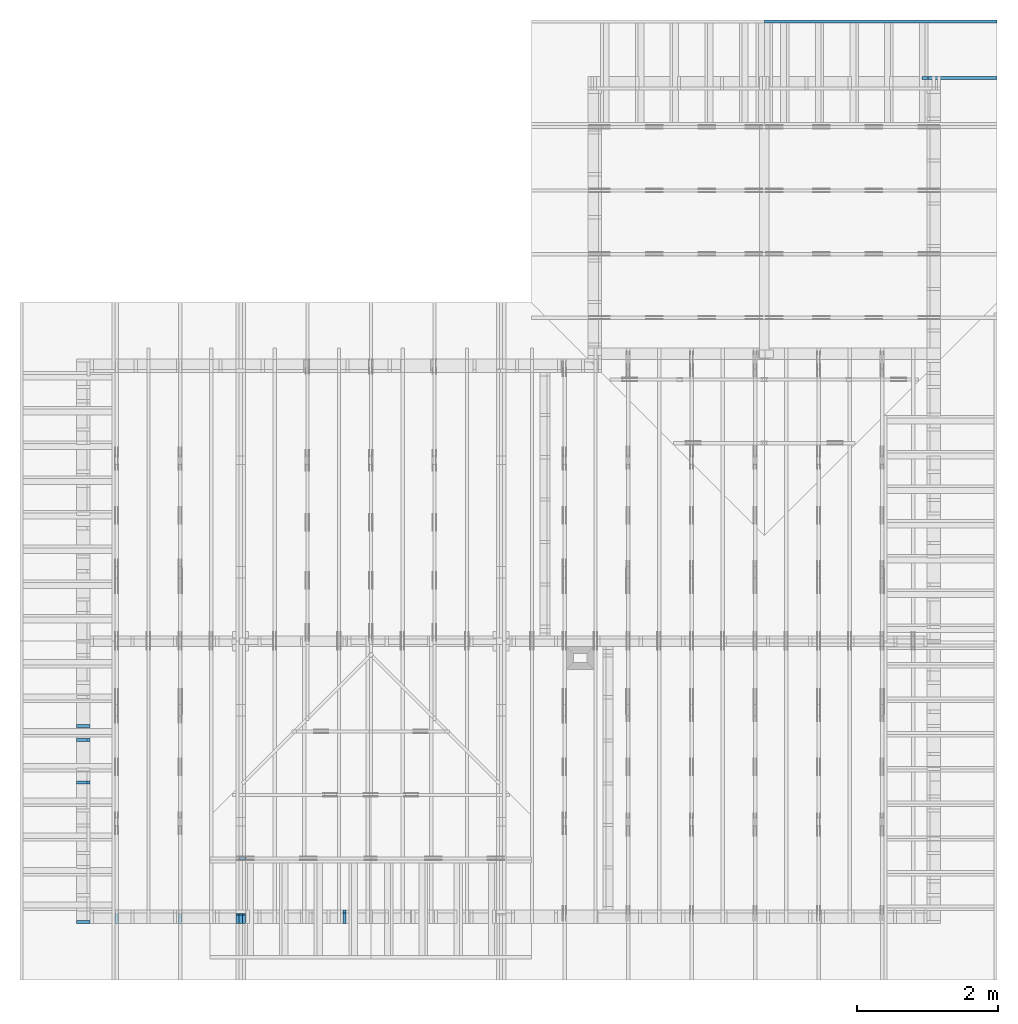
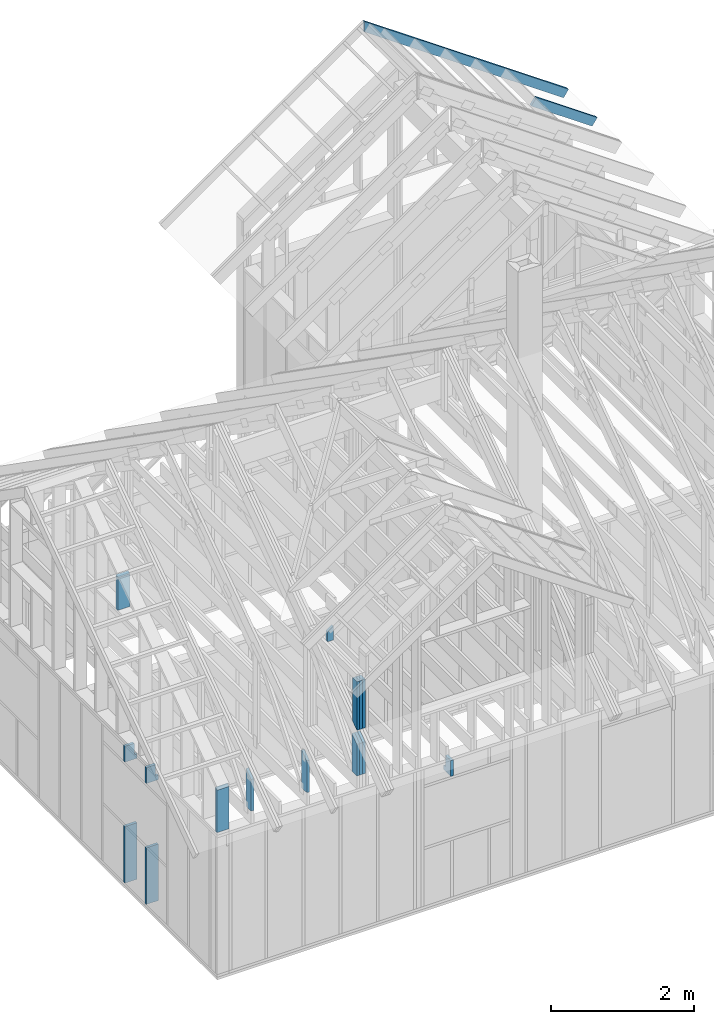
# One storey, part 36 of 70: 18 members, 8 elements without a shape of their own.
"""IFC2X3 building model written with IfcOpenShell, lengths in millimetres."""

import ifcopenshell
import ifcopenshell.guid

model = None  # the IFC model being written
_history = None  # IfcOwnerHistory: only IFC2X3 demands one
_inside = {}  # id of a spatial element -> (the spatial element, [elements in it])
_under = {}  # id of a project, library or spatial element -> (it, [spatial elements below it])
_declared = {}  # id of a project -> (the project, [libraries it declares])
_typed = {}  # id of a type object -> (the type object, [elements of that type])
_made_of = {}  # id of a material, layer set ... -> (it, [elements and type objects made of it])


def new_model(schema):
    """Start an empty IFC model of exactly this schema.

    Asked for "IFC4X3", IfcOpenShell would pick the latest addendum, in which some entities
    have other attributes; the version numbers below select the first issue.
    IFC2X3 requires an IfcOwnerHistory on every rooted entity: one is made here for all.
    """
    global model, _history
    if schema == "IFC4X3":
        model = ifcopenshell.file(schema_version=(4, 3, 0, 0))
    else:
        model = ifcopenshell.file(schema=schema)
    _inside.clear()
    _under.clear()
    _declared.clear()
    _typed.clear()
    _made_of.clear()
    _history = None
    if model.schema == "IFC2X3":
        org = make("IfcOrganization", Name="unknown")
        user = make(
            "IfcPersonAndOrganization",
            ThePerson=make("IfcPerson", FamilyName="unknown"),
            TheOrganization=org,
        )
        app = make(
            "IfcApplication",
            ApplicationDeveloper=org,
            Version="unknown",
            ApplicationFullName="unknown",
            ApplicationIdentifier="unknown",
        )
        _history = make(
            "IfcOwnerHistory",
            OwningUser=user,
            OwningApplication=app,
            ChangeAction="ADDED",
            CreationDate=0,
        )
    return model


def make(cls, **values):
    """One entity of the class cls with the attributes given. An attribute that is None is left unset."""
    return model.create_entity(
        cls, **{name: value for name, value in values.items() if value is not None}
    )


def rooted(cls, **values):
    """An entity with a GlobalId (a new one), such as an element, a storey or a relation."""
    return make(cls, GlobalId=ifcopenshell.guid.new(), OwnerHistory=_history, **values)


def si_unit(unit_type, name, prefix=None):
    """IfcSIUnit, for example si_unit("LENGTHUNIT", "METRE", prefix="MILLI")."""
    return make("IfcSIUnit", UnitType=unit_type, Prefix=prefix, Name=name)


def assignment(units):
    """IfcUnitAssignment: the units of a project."""
    return None if units is None else make("IfcUnitAssignment", Units=units)


def point(xyz):
    """IfcCartesianPoint."""
    return None if xyz is None else make("IfcCartesianPoint", Coordinates=xyz)


def direction(xyz):
    """IfcDirection."""
    return None if xyz is None else make("IfcDirection", DirectionRatios=xyz)


def frame(location, z_axis=None, x_axis=None):
    """IfcAxis2Placement3D, a coordinate frame: its origin and axes. An axis left out is left unset."""
    return make(
        "IfcAxis2Placement3D",
        Location=point(location),
        Axis=direction(z_axis),
        RefDirection=direction(x_axis),
    )


def frame_2d(location, x_axis=None):
    """IfcAxis2Placement2D, a coordinate frame in the plane: its origin and x axis."""
    return make(
        "IfcAxis2Placement2D", Location=point(location), RefDirection=direction(x_axis)
    )


def origin():
    """The frame at (0, 0, 0) with its axes left unset."""
    return frame((0.0, 0.0, 0.0))


def origin_with_axes():
    """The frame at (0, 0, 0) with the z axis (0, 0, 1) and the x axis (1, 0, 0) written out."""
    return frame((0.0, 0.0, 0.0), z_axis=(0.0, 0.0, 1.0), x_axis=(1.0, 0.0, 0.0))


def origin_2d():
    """The frame at (0, 0) in the plane with its x axis left unset."""
    return frame_2d((0.0, 0.0))


def place(relative_to, where):
    """IfcLocalPlacement: puts the frame where relative to a parent placement (None: the world)."""
    return make(
        "IfcLocalPlacement", PlacementRelTo=relative_to, RelativePlacement=where
    )


def context(
    kind, dimensions, precision=None, world=None, true_north=None, identifier=None
):
    """IfcGeometricRepresentationContext, for example the 3D "Model" context."""
    return make(
        "IfcGeometricRepresentationContext",
        ContextIdentifier=identifier,
        ContextType=kind,
        CoordinateSpaceDimension=dimensions,
        Precision=precision,
        WorldCoordinateSystem=world,
        TrueNorth=true_north,
    )


def project(units=None, contexts=None):
    """IfcProject with its units and contexts."""
    return rooted(
        "IfcProject",
        Name="project",
        RepresentationContexts=contexts,
        UnitsInContext=assignment(units),
    )


def spatial(cls, under=None, at=None, **own):
    """A site, building, storey or space (cls), placed at a placement, below another one or the project."""
    s = rooted(cls, ObjectPlacement=at, **own)
    if under is not None:
        _under.setdefault(under.id(), (under, []))[1].append(s)
    return s


def faces_of(points, faces, orient=None, outer=None):
    """IfcFace entities. A face is a list of loops; a loop is a list of indices into points, from 0.

    orient and outer hold one flag for each loop. By default every Orientation is true, the
    first loop of a face is its IfcFaceOuterBound and the others are IfcFaceBound.
    """
    made = []
    for i, loops in enumerate(faces):
        bounds = []
        for j, loop in enumerate(loops):
            is_outer = j == 0 if outer is None else outer[i][j]
            bounds.append(
                make(
                    "IfcFaceOuterBound" if is_outer else "IfcFaceBound",
                    Bound=make("IfcPolyLoop", Polygon=[points[k] for k in loop]),
                    Orientation=True if orient is None else orient[i][j],
                )
            )
        made.append(make("IfcFace", Bounds=bounds))
    return made


def faceted_brep(points, faces, orient=None, outer=None, voids=None):
    """IfcFacetedBrep: a solid bounded by flat faces; with voids (closed shells), ...WithVoids."""
    shared = [point(p) for p in points]
    hull = make("IfcClosedShell", CfsFaces=faces_of(shared, faces, orient, outer))
    if voids is None:
        return make("IfcFacetedBrep", Outer=hull)
    return make(
        "IfcFacetedBrepWithVoids",
        Outer=hull,
        Voids=[
            make(cls, CfsFaces=faces_of(shared, fs, o, b)) for cls, fs, o, b in voids
        ],
    )


def shape(context_of_items, identifier, shape_type, items):
    """IfcShapeRepresentation: the items that make up one representation, for example the "Body"."""
    return make(
        "IfcShapeRepresentation",
        ContextOfItems=context_of_items,
        RepresentationIdentifier=identifier,
        RepresentationType=shape_type,
        Items=items,
    )


def made_of(thing, what):
    """Note that an element or type object is made of a material, layer set ...; save() writes the relation."""
    if what is not None:
        _made_of.setdefault(what.id(), (what, []))[1].append(thing)
    return thing


def element(
    cls,
    number,
    at=None,
    inside=None,
    cuts=None,
    type_object=None,
    material=None,
    context=None,
    identifier="Body",
    shape_type=None,
    held_by="IfcProductDefinitionShape",
    body=None,
    shapes=None,
    **own,
):
    """One element of the class cls, such as IfcWall. Its Tag is "e" and its number.

    at: its placement. inside: the storey or other place that contains it. cuts: it is an
    opening in that element (IfcRelVoidsElement). A single representation is given by context,
    identifier, shape_type and body (its items); several are given by shapes. held_by: the class
    of the entity that holds the representations. save() writes the other relations.
    """
    e = rooted(cls, Tag="e%d" % number, ObjectPlacement=at, **own)
    if body is not None:
        shapes = [shape(context, identifier, shape_type, body)]
    if shapes is not None:
        e.Representation = make(held_by, Representations=shapes)
    if inside is not None:
        _inside.setdefault(inside.id(), (inside, []))[1].append(e)
    if cuts is not None:
        rooted(
            "IfcRelVoidsElement", RelatingBuildingElement=cuts, RelatedOpeningElement=e
        )
    if type_object is not None:
        _typed.setdefault(type_object.id(), (type_object, []))[1].append(e)
    return made_of(e, material)


def aggregate(whole, parts):
    """IfcRelAggregates: a whole, such as a stair, and the parts it consists of."""
    return rooted("IfcRelAggregates", RelatingObject=whole, RelatedObjects=parts)


def save(model, path):
    """Write the relations noted so far, then the file.

    IfcRelAggregates (storeys below a building ...), IfcRelContainedInSpatialStructure (elements
    in a storey), IfcRelDefinesByType, IfcRelAssociatesMaterial and IfcRelDeclares: one each for
    every whole, place, type object, material and project.
    """
    for whole, parts in _under.values():
        aggregate(whole, parts)
    for where, things in _inside.values():
        rooted(
            "IfcRelContainedInSpatialStructure",
            RelatedElements=things,
            RelatingStructure=where,
        )
    for kind, things in _typed.values():
        rooted("IfcRelDefinesByType", RelatedObjects=things, RelatingType=kind)
    for what, things in _made_of.values():
        rooted("IfcRelAssociatesMaterial", RelatedObjects=things, RelatingMaterial=what)
    for by, libraries in _declared.values():
        rooted("IfcRelDeclares", RelatingContext=by, RelatedDefinitions=libraries)
    model.write(path)


model = new_model("IFC2X3")

# Units and contexts
model_context = context("Model", 3, precision=1e-05, world=origin())
plan_context = context("Plan", 2, precision=1e-05, world=origin_2d())
ifc_project = project(units=[si_unit("LENGTHUNIT", "METRE", prefix="MILLI"), si_unit("AREAUNIT", "SQUARE_METRE"), si_unit("VOLUMEUNIT", "CUBIC_METRE"), si_unit("SOLIDANGLEUNIT", "STERADIAN"), si_unit("PLANEANGLEUNIT", "RADIAN"), si_unit("MASSUNIT", "GRAM"), si_unit("TIMEUNIT", "SECOND"), si_unit("THERMODYNAMICTEMPERATUREUNIT", "DEGREE_CELSIUS"), si_unit("LUMINOUSINTENSITYUNIT", "LUMEN")], contexts=[model_context, plan_context])

# Site, building, storey
site_placement = place(None, origin_with_axes())
site = spatial("IfcSite", under=ifc_project, at=site_placement, CompositionType="ELEMENT")
building_placement = place(site_placement, origin_with_axes())
building = spatial("IfcBuilding", under=site, at=building_placement, Name="Layout 1", CompositionType="ELEMENT")
storey_placement = place(building_placement, origin_with_axes())
storey = spatial("IfcBuildingStorey", under=building, at=storey_placement, Name="Storey 1", CompositionType="ELEMENT", Elevation=0.0)

# Assembly, members
assembly_1_placement = place(storey_placement, frame((1969.9999999999982, 8000.000000000001, 1.1021457184401395e-14), z_axis=(-1.0, 1.836909530733566e-16, 6.123031769111886e-17), x_axis=(-1.836909530733566e-16, -1.0, 0.0)))
assembly_1 = element("IfcElementAssembly", 1, at=assembly_1_placement, inside=storey, Name="T11", AssemblyPlace="FACTORY", PredefinedType="TRUSS")
member_1_placement = place(assembly_1_placement, frame((7855.0, 863.4790482301833, -90.0), z_axis=(0.0, 0.0, 1.0), x_axis=(-1.836909530733566e-16, -1.0, 0.0)))
member_1 = element("IfcMember", 2, at=member_1_placement, Name="E3", context=model_context, shape_type="Brep", body=[
    faceted_brep([(643.4790482301834, 145.0, 45.0), (101.53009304048464, 145.0, 45.0), (0.0, 1.8480932340025902e-09, 45.0), (643.4790482301834, 1.8480932340025902e-09, 45.0), (101.53009304048464, 145.0, 1.2433439704155462e-14), (643.4790482301834, 145.0, 7.880085310142585e-14), (643.4790482301834, 1.8480932340025902e-09, 7.880085310142585e-14), (0.0, 1.8480932340025902e-09, 0.0), (5.452511878872964e-15, 1.8480894161126704e-09, -4.075666256077759e-31), (7.70957417477943e-15, 1.8480878357006368e-09, 45.0), (101.53009304048466, 145.00000000183354, 45.0), (101.53009304048466, 145.00000000183354, 3.1438766626360792e-31), (643.4790482301834, -3.3424355386735616e-13, 2.0465838989515024e-29), (643.4790482301834, -3.314881895712558e-13, 45.0), (7.91492914862017e-27, 1.8480959893668863e-09, 45.0), (0.0, 1.8480932340025902e-09, 0.0), (643.4790482301834, 145.0, 0.0), (643.4790482301834, 145.0, 45.0), (643.4790482301834, 0.0, 45.0), (643.4790482301834, 0.0, 0.0), (101.53009304048464, 145.00000000183357, 1.5777218104420236e-30), (101.53009304048464, 145.00000000183354, 45.0), (643.4790482301834, 145.00000000000006, 45.0), (643.4790482301834, 145.00000000000006, 4.733165431326071e-30)], [[[0, 1, 2, 3]], [[4, 5, 6, 7]], [[8, 9, 10, 11]], [[12, 13, 14, 15]], [[16, 17, 18, 19]], [[20, 21, 22, 23]]]),
])
member_2_placement = place(assembly_1_placement, frame((7855.0, 863.4790482301833, -135.0), z_axis=(0.0, 0.0, 1.0), x_axis=(-1.836909530733566e-16, -1.0, 0.0)))
member_2 = element("IfcMember", 3, at=member_2_placement, Name="E3", context=model_context, shape_type="Brep", body=[
    faceted_brep([(643.4790482301834, 145.0, 45.0), (101.53009304048464, 145.0, 45.0), (0.0, 1.8480932340025902e-09, 45.0), (643.4790482301834, 1.8480932340025902e-09, 45.0), (101.53009304048464, 145.0, 1.2433439704155462e-14), (643.4790482301834, 145.0, 7.880085310142585e-14), (643.4790482301834, 1.8480932340025902e-09, 7.880085310142585e-14), (0.0, 1.8480932340025902e-09, 0.0), (5.452511878872964e-15, 1.8480894161126704e-09, -4.075666256077759e-31), (7.70957417477943e-15, 1.8480878357006368e-09, 45.0), (101.53009304048466, 145.00000000183354, 45.0), (101.53009304048466, 145.00000000183354, 3.1438766626360792e-31), (643.4790482301834, -3.3424355386735616e-13, 2.0465838989515024e-29), (643.4790482301834, -3.314881895712558e-13, 45.0), (7.91492914862017e-27, 1.8480959893668863e-09, 45.0), (0.0, 1.8480932340025902e-09, 0.0), (643.4790482301834, 145.0, 0.0), (643.4790482301834, 145.0, 45.0), (643.4790482301834, 0.0, 45.0), (643.4790482301834, 0.0, 0.0), (101.53009304048464, 145.00000000183357, 1.5777218104420236e-30), (101.53009304048464, 145.00000000183354, 45.0), (643.4790482301834, 145.00000000000006, 45.0), (643.4790482301834, 145.00000000000006, 4.733165431326071e-30)], [[[0, 1, 2, 3]], [[4, 5, 6, 7]], [[8, 9, 10, 11]], [[12, 13, 14, 15]], [[16, 17, 18, 19]], [[20, 21, 22, 23]]]),
])
member_3_placement = place(assembly_1_placement, frame((7855.0, 863.4790482301833, -180.0), z_axis=(0.0, 0.0, 1.0), x_axis=(-1.836909530733566e-16, -1.0, 0.0)))
member_3 = element("IfcMember", 4, at=member_3_placement, Name="E3", context=model_context, shape_type="Brep", body=[
    faceted_brep([(643.4790482301834, 145.0, 45.0), (101.53009304048464, 145.0, 45.0), (0.0, 1.8480932340025902e-09, 45.0), (643.4790482301834, 1.8480932340025902e-09, 45.0), (101.53009304048464, 145.0, 1.2433439704155462e-14), (643.4790482301834, 145.0, 7.880085310142585e-14), (643.4790482301834, 1.8480932340025902e-09, 7.880085310142585e-14), (0.0, 1.8480932340025902e-09, 0.0), (5.452511878872964e-15, 1.8480894161126704e-09, -4.075666256077759e-31), (7.70957417477943e-15, 1.8480878357006368e-09, 45.0), (101.53009304048466, 145.00000000183354, 45.0), (101.53009304048466, 145.00000000183354, 3.1438766626360792e-31), (643.4790482301834, -3.3424355386735616e-13, 2.0465838989515024e-29), (643.4790482301834, -3.314881895712558e-13, 45.0), (7.91492914862017e-27, 1.8480959893668863e-09, 45.0), (0.0, 1.8480932340025902e-09, 0.0), (643.4790482301834, 145.0, 0.0), (643.4790482301834, 145.0, 45.0), (643.4790482301834, 0.0, 45.0), (643.4790482301834, 0.0, 0.0), (101.53009304048464, 145.00000000183357, 1.5777218104420236e-30), (101.53009304048464, 145.00000000183354, 45.0), (643.4790482301834, 145.00000000000006, 45.0), (643.4790482301834, 145.00000000000006, 4.733165431326071e-30)], [[[0, 1, 2, 3]], [[4, 5, 6, 7]], [[8, 9, 10, 11]], [[12, 13, 14, 15]], [[16, 17, 18, 19]], [[20, 21, 22, 23]]]),
])
member_4_placement = place(assembly_1_placement, frame((8000.000000033557, 999.99999997759, -90.0), z_axis=(0.0, 0.0, 1.0), x_axis=(-2.7770506434796755e-12, 1.0, 0.0)))
member_4 = element("IfcMember", 5, at=member_4_placement, Name="E5", context=model_context, shape_type="Brep", body=[
    faceted_brep([(830.4396159941855, 120.00000002938759, 45.0), (84.0249045856458, 120.00000002938759, 45.0), (0.0, 0.0, 45.0), (830.4396159939456, 0.0, 45.0), (84.0249045856458, 120.00000002938759, 1.0289743203490085e-14), (830.4396159941855, 120.00000002938759, 1.0169616302122946e-13), (830.4396159939456, 0.0, 1.0169616302120009e-13), (0.0, 0.0, 0.0), (0.0, 0.0, 0.0), (2.2570622959073368e-15, -1.580412033812092e-15, 45.0), (84.02490458564581, 120.00000000001366, 45.0), (84.02490458564581, 120.00000000001366, 0.0), (830.4396159939456, 3.124957528378116e-08, 4.057544176123283e-29), (830.4396159939456, 3.124957803914546e-08, 45.0), (-1.0368479820435048e-25, 2.755364296100349e-15, 45.0), (0.0, 0.0, 0.0), (830.4396159939456, 120.00000002938759, -1.4685434611594356e-26), (830.4396159939456, 120.00000002938759, 45.0), (830.4396159939456, 3.1250237952917814e-08, 45.0), (830.4396159939456, 3.1250237952917814e-08, 0.0), (84.02490458564579, 120.00000000001364, 0.0), (84.02490458564579, 120.00000000001363, 45.0), (830.4396159941855, 120.00000002938755, 45.0), (830.4396159941855, 120.00000002938755, -3.1554436208840472e-30)], [[[0, 1, 2, 3]], [[4, 5, 6, 7]], [[8, 9, 10, 11]], [[12, 13, 14, 15]], [[16, 17, 18, 19]], [[20, 21, 22, 23]]]),
])
member_5_placement = place(assembly_1_placement, frame((8000.000000033557, 999.99999997759, -135.0), z_axis=(0.0, 0.0, 1.0), x_axis=(-2.7770506434796755e-12, 1.0, 0.0)))
member_5 = element("IfcMember", 6, at=member_5_placement, Name="E5", context=model_context, shape_type="Brep", body=[
    faceted_brep([(830.4396159941855, 120.00000002938759, 45.0), (84.0249045856458, 120.00000002938759, 45.0), (0.0, 0.0, 45.0), (830.4396159939456, 0.0, 45.0), (84.0249045856458, 120.00000002938759, 1.0289743203490085e-14), (830.4396159941855, 120.00000002938759, 1.0169616302122946e-13), (830.4396159939456, 0.0, 1.0169616302120009e-13), (0.0, 0.0, 0.0), (0.0, 0.0, 0.0), (2.2570622959073368e-15, -1.580412033812092e-15, 45.0), (84.02490458564581, 120.00000000001366, 45.0), (84.02490458564581, 120.00000000001366, 0.0), (830.4396159939456, 3.124957528378116e-08, 4.057544176123283e-29), (830.4396159939456, 3.124957803914546e-08, 45.0), (-1.0368479820435048e-25, 2.755364296100349e-15, 45.0), (0.0, 0.0, 0.0), (830.4396159939456, 120.00000002938759, -1.4685434611594356e-26), (830.4396159939456, 120.00000002938759, 45.0), (830.4396159939456, 3.1250237952917814e-08, 45.0), (830.4396159939456, 3.1250237952917814e-08, 0.0), (84.02490458564579, 120.00000000001364, 0.0), (84.02490458564579, 120.00000000001363, 45.0), (830.4396159941855, 120.00000002938755, 45.0), (830.4396159941855, 120.00000002938755, -3.1554436208840472e-30)], [[[0, 1, 2, 3]], [[4, 5, 6, 7]], [[8, 9, 10, 11]], [[12, 13, 14, 15]], [[16, 17, 18, 19]], [[20, 21, 22, 23]]]),
])
member_6_placement = place(assembly_1_placement, frame((8000.000000033557, 999.99999997759, -180.0), z_axis=(0.0, 0.0, 1.0), x_axis=(-2.7770506434796755e-12, 1.0, 0.0)))
member_6 = element("IfcMember", 7, at=member_6_placement, Name="E5", context=model_context, shape_type="Brep", body=[
    faceted_brep([(830.4396159941855, 120.00000002938759, 45.0), (84.0249045856458, 120.00000002938759, 45.0), (0.0, 0.0, 45.0), (830.4396159939456, 0.0, 45.0), (84.0249045856458, 120.00000002938759, 1.0289743203490085e-14), (830.4396159941855, 120.00000002938759, 1.0169616302122946e-13), (830.4396159939456, 0.0, 1.0169616302120009e-13), (0.0, 0.0, 0.0), (0.0, 0.0, 0.0), (2.2570622959073368e-15, -1.580412033812092e-15, 45.0), (84.02490458564581, 120.00000000001366, 45.0), (84.02490458564581, 120.00000000001366, 0.0), (830.4396159939456, 3.124957528378116e-08, 4.057544176123283e-29), (830.4396159939456, 3.124957803914546e-08, 45.0), (-1.0368479820435048e-25, 2.755364296100349e-15, 45.0), (0.0, 0.0, 0.0), (830.4396159939456, 120.00000002938759, -1.4685434611594356e-26), (830.4396159939456, 120.00000002938759, 45.0), (830.4396159939456, 3.1250237952917814e-08, 45.0), (830.4396159939456, 3.1250237952917814e-08, 0.0), (84.02490458564579, 120.00000000001364, 0.0), (84.02490458564579, 120.00000000001363, 45.0), (830.4396159941855, 120.00000002938755, 45.0), (830.4396159941855, 120.00000002938755, -3.1554436208840472e-30)], [[[0, 1, 2, 3]], [[4, 5, 6, 7]], [[8, 9, 10, 11]], [[12, 13, 14, 15]], [[16, 17, 18, 19]], [[20, 21, 22, 23]]]),
])
aggregate(assembly_1, [member_1, member_2, member_3, member_4, member_5, member_6])

# Assembly, member
assembly_2_placement = place(storey_placement, frame((304.9999999999989, 8000.000000000001, 1.3776821480501744e-15), z_axis=(-1.0, 1.836909530733566e-16, 6.123031769111886e-17), x_axis=(-1.836909530733566e-16, -1.0, 0.0)))
assembly_2 = element("IfcElementAssembly", 8, at=assembly_2_placement, inside=storey, Name="T2", AssemblyPlace="FACTORY", PredefinedType="TRUSS")
member_7_placement = place(assembly_2_placement, frame((7855.0, 863.4790482301833, -45.0), z_axis=(0.0, 0.0, 1.0), x_axis=(-1.836909530733566e-16, -1.0, 0.0)))
member_7 = element("IfcMember", 9, at=member_7_placement, Name="E3", context=model_context, shape_type="Brep", body=[
    faceted_brep([(643.4790482301833, 145.0, 45.0), (101.53009304048464, 145.0, 45.0), (0.0, 1.8480932340025902e-09, 45.0), (643.4790482301833, 1.8480932340025902e-09, 45.0), (101.53009304048464, 145.0, 1.2433439704155462e-14), (643.4790482301833, 145.0, 7.880085310142583e-14), (643.4790482301833, 1.8480932340025902e-09, 7.880085310142583e-14), (0.0, 1.8480932340025902e-09, 0.0), (5.452511878872964e-15, 1.8480894161126704e-09, -4.075666256077759e-31), (7.70957417477943e-15, 1.8480878357006368e-09, 45.0), (101.53009304048466, 145.00000000183354, 45.0), (101.53009304048466, 145.00000000183354, 3.1438766626360792e-31), (643.4790482301833, -3.3424355386714936e-13, 2.0465838989492066e-29), (643.4790482301833, -3.31488189571049e-13, 45.0), (7.91492914862017e-27, 1.8480959893668863e-09, 45.0), (0.0, 1.8480932340025902e-09, 0.0), (643.4790482301833, 145.0, 0.0), (643.4790482301833, 145.0, 45.0), (643.4790482301833, 0.0, 45.0), (643.4790482301833, 0.0, 0.0), (101.53009304048464, 145.00000000183357, 1.5777218104420236e-30), (101.53009304048464, 145.00000000183354, 45.0), (643.4790482301833, 145.00000000000006, 45.0), (643.4790482301833, 145.00000000000006, 4.733165431326071e-30)], [[[0, 1, 2, 3]], [[4, 5, 6, 7]], [[8, 9, 10, 11]], [[12, 13, 14, 15]], [[16, 17, 18, 19]], [[20, 21, 22, 23]]]),
])
aggregate(assembly_2, [member_7])

assembly_3_placement = place(storey_placement, frame((1204.9999999999989, 8000.000000000001, 1.3776821480501744e-15), z_axis=(-1.0, 1.836909530733566e-16, 6.123031769111886e-17), x_axis=(-1.836909530733566e-16, -1.0, 0.0)))
assembly_3 = element("IfcElementAssembly", 10, at=assembly_3_placement, inside=storey, Name="T2", AssemblyPlace="FACTORY", PredefinedType="TRUSS")
member_8_placement = place(assembly_3_placement, frame((7855.0, 863.4790482301833, -45.0), z_axis=(0.0, 0.0, 1.0), x_axis=(-1.836909530733566e-16, -1.0, 0.0)))
member_8 = element("IfcMember", 11, at=member_8_placement, Name="E3", context=model_context, shape_type="Brep", body=[
    faceted_brep([(643.4790482301833, 145.0, 45.0), (101.53009304048464, 145.0, 45.0), (0.0, 1.8480932340025902e-09, 45.0), (643.4790482301833, 1.8480932340025902e-09, 45.0), (101.53009304048464, 145.0, 1.2433439704155462e-14), (643.4790482301833, 145.0, 7.880085310142583e-14), (643.4790482301833, 1.8480932340025902e-09, 7.880085310142583e-14), (0.0, 1.8480932340025902e-09, 0.0), (5.452511878872964e-15, 1.8480894161126704e-09, -4.075666256077759e-31), (7.70957417477943e-15, 1.8480878357006368e-09, 45.0), (101.53009304048466, 145.00000000183354, 45.0), (101.53009304048466, 145.00000000183354, 3.1438766626360792e-31), (643.4790482301833, -3.3424355386714936e-13, 2.0465838989492066e-29), (643.4790482301833, -3.31488189571049e-13, 45.0), (7.91492914862017e-27, 1.8480959893668863e-09, 45.0), (0.0, 1.8480932340025902e-09, 0.0), (643.4790482301833, 145.0, 0.0), (643.4790482301833, 145.0, 45.0), (643.4790482301833, 0.0, 45.0), (643.4790482301833, 0.0, 0.0), (101.53009304048464, 145.00000000183357, 1.5777218104420236e-30), (101.53009304048464, 145.00000000183354, 45.0), (643.4790482301833, 145.00000000000006, 45.0), (643.4790482301833, 145.00000000000006, 4.733165431326071e-30)], [[[0, 1, 2, 3]], [[4, 5, 6, 7]], [[8, 9, 10, 11]], [[12, 13, 14, 15]], [[16, 17, 18, 19]], [[20, 21, 22, 23]]]),
])
aggregate(assembly_3, [member_8])

assembly_4_placement = place(storey_placement, frame((6205.00000000017, 945.0, 1.3776821480501744e-15), z_axis=(1.2246063538223773e-16, 1.0, 6.123031769111886e-17), x_axis=(-1.0, 1.2246063538223773e-16, 0.0)))
assembly_4 = element("IfcElementAssembly", 12, at=assembly_4_placement, inside=storey, Name="T7", AssemblyPlace="FACTORY", PredefinedType="TRUSS")
member_9_placement = place(assembly_4_placement, frame((4050.0, 2185.449992880698, -45.0), z_axis=(0.0, 0.0, 1.0), x_axis=(-1.836909530733566e-16, -1.0, 0.0)))
member_9 = element("IfcMember", 13, at=member_9_placement, Name="E6", context=model_context, shape_type="Brep", body=[
    faceted_brep([(235.01037691396073, 95.00000000000045, 45.0), (66.51971612997295, 95.00000000000045, 45.0), (0.0, 2.0081643015146255e-09, 45.0), (235.01037691396073, 2.0081643015146255e-09, 45.0), (66.51971612997295, 95.00000000000045, 8.146046702722574e-15), (235.01037691396073, 95.00000000000045, 2.87795200783028e-14), (235.01037691396073, 2.0081643015146255e-09, 2.87795200783028e-14), (0.0, 2.0081643015146255e-09, 0.0), (-3.1037571806482696e-15, 2.0081664747888e-09, 2.320009325875306e-31), (-8.466948847418045e-16, 2.0081648943767664e-09, 45.0), (66.51971612997296, 95.00000000200862, 45.0), (66.51971612997296, 95.00000000200862, 1.789188918335742e-31), (235.01037691396073, -8.121554777926581e-14, 4.9728537919822965e-30), (235.01037691396073, -7.846018348316546e-14, 45.0), (2.35455475112219e-26, 2.0081670568789216e-09, 45.0), (0.0, 2.0081643015146255e-09, 0.0), (235.01037691396073, 95.00000000000045, 0.0), (235.01037691396073, 95.00000000000045, 45.0), (235.01037691396073, 0.0, 45.0), (235.01037691396073, 0.0, 0.0), (66.51971612997295, 95.00000000200862, 7.888609052210118e-31), (66.51971612997295, 95.00000000200862, 45.0), (235.01037691396073, 95.00000000000047, 45.0), (235.01037691396073, 95.00000000000047, 7.888609052210118e-31)], [[[0, 1, 2, 3]], [[4, 5, 6, 7]], [[8, 9, 10, 11]], [[12, 13, 14, 15]], [[16, 17, 18, 19]], [[20, 21, 22, 23]]]),
])
aggregate(assembly_4, [member_9])

# Assembly, members
assembly_5_placement = place(storey_placement, frame((-243.55339059327574, 8000.000000000001, -2470.0), z_axis=(-1.0, 1.836909530733566e-16, 6.123031769111886e-17), x_axis=(-1.836909530733566e-16, -1.0, 0.0)))
assembly_5 = element("IfcElementAssembly", 14, at=assembly_5_placement, inside=storey, Name="VE3", AssemblyPlace="FACTORY", PredefinedType="NOTDEFINED")
member_10_placement = place(assembly_5_placement, frame((5377.5000000018335, 2425.0, -195.00000000000003), z_axis=(0.0, 0.0, 1.0), x_axis=(-1.836909530733566e-16, -1.0, 0.0)))
member_10 = element("IfcMember", 15, at=member_10_placement, Name="S40", context=model_context, shape_type="Brep", body=[
    faceted_brep([(0.0, 45.0, 45.00000000000003), (195.00000000186265, 45.0, 45.00000000000005), (195.00000000186265, 0.0, 45.00000000000005), (0.0, 0.0, 45.00000000000003), (195.00000000186265, 45.0, 2.842170943040401e-14), (195.00000000186265, 45.0, 45.00000000000003), (195.00000000186265, 0.0, 45.00000000000003), (195.00000000186265, 0.0, 2.842170943040401e-14), (2.7553642961003504e-15, -3.3742366240998114e-31, 45.00000000000003), (1.193991194976818e-14, -1.4621692037765842e-30, 195.00000000000003), (1.7450640541968876e-14, 45.0, 195.00000000000003), (8.266092888301048e-15, 45.0, 45.00000000000003), (270.0, -4.959655732980628e-14, 2.842170943040401e-14), (270.0, -3.76566453800381e-14, 195.00000000000003), (2.1932538056648764e-30, 1.193991194976818e-14, 195.00000000000003), (5.061354936149717e-31, 2.7553642961003504e-15, 45.00000000000003), (195.00000000186265, -3.306437155354634e-14, 45.00000000000003), (195.00000000186265, -3.5819735849646686e-14, 2.842170943040401e-14), (-1.6871183120499057e-31, 45.0, 45.00000000000003), (-7.310846018882921e-31, 44.999999999999986, 195.00000000000003), (270.0, 44.99999999999997, 195.00000000000003), (270.0, 44.999999999999986, 2.842170943040401e-14), (195.00000000186265, 44.999999999999986, 2.842170943040401e-14), (195.00000000186265, 44.999999999999986, 45.00000000000003), (270.0, 45.0, 0.0), (270.0, 45.0, 195.00000000000003), (270.0, 0.0, 195.00000000000003), (270.0, 0.0, 0.0), (270.0, 45.0, 195.00000000000003), (0.0, 45.0, 195.00000000000003), (0.0, 0.0, 195.00000000000003), (270.0, 0.0, 195.00000000000003), (195.00000000186265, 45.0, 5.2301533330168465e-14), (270.0, 45.0, 6.148608098360819e-14), (270.0, 0.0, 6.148608098360819e-14), (195.00000000186265, 0.0, 5.2301533330168465e-14)], [[[0, 1, 2, 3]], [[4, 5, 6, 7]], [[8, 9, 10, 11]], [[12, 13, 14, 15, 16, 17]], [[18, 19, 20, 21, 22, 23]], [[24, 25, 26, 27]], [[28, 29, 30, 31]], [[32, 33, 34, 35]]]),
])
member_11_placement = place(assembly_5_placement, frame((5377.500000001819, 1055.0, -195.0), z_axis=(0.0, 0.0, 1.0), x_axis=(-1.836909530733566e-16, -1.0, 0.0)))
member_11 = element("IfcMember", 16, at=member_11_placement, Name="S32", context=model_context, shape_type="Brep", body=[
    faceted_brep([(964.9999999999999, 45.00000000001455, 195.0), (0.0, 45.00000000001455, 195.0), (0.0, 2.9103830456733704e-11, 195.0), (964.9999999999999, 2.9103830456733704e-11, 195.0), (0.0, 45.00000000001455, 0.0), (964.9999999999999, 45.00000000001455, 1.1817451314385938e-13), (964.9999999999999, 2.9103830456733704e-11, 1.1817451314385938e-13), (0.0, 2.9103830456733704e-11, 0.0), (3.564073569788531e-27, 2.9103830456733704e-11, -2.1822935695267187e-43), (1.1939911949771742e-14, 2.9103830456733704e-11, 195.0), (1.7450640541972442e-14, 45.000000000029104, 195.0), (5.510728592204262e-15, 45.000000000029104, -3.3742366241019913e-31), (964.9999999999999, 6.425269116674297e-13, -3.934212692649035e-29), (964.9999999999999, 6.544668236171979e-13, 195.0), (3.5215073399348835e-28, 2.911577036868347e-11, 195.0), (0.0, 2.9103830456733704e-11, 0.0), (964.9999999999999, 45.00000000001455, 0.0), (964.9999999999999, 45.00000000001455, 195.0), (964.9999999999999, 0.0, 195.0), (964.9999999999999, 0.0, 0.0), (0.0, 45.000000000029104, 0.0), (-2.0194839173657902e-28, 45.00000000002909, 195.0), (964.9999999999999, 45.00000000001446, 195.0), (964.9999999999999, 45.000000000014474, -4.733165431326071e-30)], [[[0, 1, 2, 3]], [[4, 5, 6, 7]], [[8, 9, 10, 11]], [[12, 13, 14, 15]], [[16, 17, 18, 19]], [[20, 21, 22, 23]]]),
])
member_12_placement = place(assembly_5_placement, frame((5977.5000000018335, 2425.0, -195.00000000000003), z_axis=(0.0, 0.0, 1.0), x_axis=(-1.836909530733566e-16, -1.0, 0.0)))
member_12 = element("IfcMember", 17, at=member_12_placement, Name="S40", context=model_context, shape_type="Brep", body=[
    faceted_brep([(0.0, 45.0, 45.00000000000003), (195.00000000186265, 45.0, 45.00000000000005), (195.00000000186265, 0.0, 45.00000000000005), (0.0, 0.0, 45.00000000000003), (195.00000000186265, 45.0, 2.842170943040401e-14), (195.00000000186265, 45.0, 45.00000000000003), (195.00000000186265, 0.0, 45.00000000000003), (195.00000000186265, 0.0, 2.842170943040401e-14), (2.7553642961003504e-15, -3.3742366240998114e-31, 45.00000000000003), (1.193991194976818e-14, -1.4621692037765842e-30, 195.00000000000003), (1.7450640541968876e-14, 45.0, 195.00000000000003), (8.266092888301048e-15, 45.0, 45.00000000000003), (270.0, -4.959655732980628e-14, 2.842170943040401e-14), (270.0, -3.76566453800381e-14, 195.00000000000003), (2.1932538056648764e-30, 1.193991194976818e-14, 195.00000000000003), (5.061354936149717e-31, 2.7553642961003504e-15, 45.00000000000003), (195.00000000186265, -3.306437155354634e-14, 45.00000000000003), (195.00000000186265, -3.5819735849646686e-14, 2.842170943040401e-14), (-1.6871183120499057e-31, 45.0, 45.00000000000003), (-7.310846018882921e-31, 44.999999999999986, 195.00000000000003), (270.0, 44.99999999999997, 195.00000000000003), (270.0, 44.999999999999986, 2.842170943040401e-14), (195.00000000186265, 44.999999999999986, 2.842170943040401e-14), (195.00000000186265, 44.999999999999986, 45.00000000000003), (270.0, 45.0, 0.0), (270.0, 45.0, 195.00000000000003), (270.0, 0.0, 195.00000000000003), (270.0, 0.0, 0.0), (270.0, 45.0, 195.00000000000003), (0.0, 45.0, 195.00000000000003), (0.0, 0.0, 195.00000000000003), (270.0, 0.0, 195.00000000000003), (195.00000000186265, 45.0, 5.2301533330168465e-14), (270.0, 45.0, 6.148608098360819e-14), (270.0, 0.0, 6.148608098360819e-14), (195.00000000186265, 0.0, 5.2301533330168465e-14)], [[[0, 1, 2, 3]], [[4, 5, 6, 7]], [[8, 9, 10, 11]], [[12, 13, 14, 15, 16, 17]], [[18, 19, 20, 21, 22, 23]], [[24, 25, 26, 27]], [[28, 29, 30, 31]], [[32, 33, 34, 35]]]),
])
member_13_placement = place(assembly_5_placement, frame((5977.5000000018335, 1055.0, -195.0), z_axis=(0.0, 0.0, 1.0), x_axis=(-1.836909530733566e-16, -1.0, 0.0)))
member_13 = element("IfcMember", 18, at=member_13_placement, Name="S32", context=model_context, shape_type="Brep", body=[
    faceted_brep([(965.0, 45.0, 195.0), (0.0, 45.0, 195.0), (0.0, 0.0, 195.0), (965.0, 0.0, 195.0), (0.0, 45.0, 0.0), (965.0, 45.0, 1.181745131438594e-13), (965.0, 0.0, 1.181745131438594e-13), (0.0, 0.0, 0.0), (0.0, 0.0, 0.0), (1.1939911949768178e-14, -1.462169203776584e-30, 195.0), (1.745064054197066e-14, 45.00000000001455, 195.0), (5.51072859220248e-15, 45.00000000001455, -3.3742366241009005e-31), (965.0, -1.772617697157891e-13, 1.085379447418772e-29), (965.0, -1.6532185776602093e-13, 195.0), (2.193253805664876e-30, 1.1939911949768178e-14, 195.0), (0.0, 0.0, 0.0), (965.0, 45.0, 0.0), (965.0, 45.0, 195.0), (965.0, 0.0, 195.0), (965.0, 0.0, 0.0), (0.0, 45.00000000001455, 0.0), (-2.0194839173657902e-28, 45.00000000001454, 195.0), (965.0, 44.99999999999991, 195.0), (965.0, 44.99999999999992, -4.733165431326071e-30)], [[[0, 1, 2, 3]], [[4, 5, 6, 7]], [[8, 9, 10, 11]], [[12, 13, 14, 15]], [[16, 17, 18, 19]], [[20, 21, 22, 23]]]),
])
aggregate(assembly_5, [member_10, member_11, member_12, member_13])

# Assembly, member
assembly_6_placement = place(storey_placement, frame((-48.55339059325575, 0.0, -2470.0), z_axis=(0.0, -1.0, 6.123031769111886e-17), x_axis=(1.0, 0.0, 0.0)))
assembly_6 = element("IfcElementAssembly", 19, at=assembly_6_placement, inside=storey, Name="VE4", AssemblyPlace="FACTORY", PredefinedType="NOTDEFINED")
member_14_placement = place(assembly_6_placement, frame((3577.500000001819, 2425.0, -195.0), z_axis=(0.0, 0.0, 1.0), x_axis=(-1.836909530733566e-16, -1.0, 0.0)))
member_14 = element("IfcMember", 20, at=member_14_placement, Name="S40", context=model_context, shape_type="Brep", body=[
    faceted_brep([(0.0, 45.0, 45.0), (195.00000000186265, 45.0, 45.00000000000002), (195.00000000186265, 1.4551915228366852e-11, 45.00000000000002), (0.0, 1.4551915228366852e-11, 45.0), (195.00000000186265, 45.00000000001046, 0.0), (195.00000000186265, 45.00000000001046, 45.0), (195.00000000186265, 4.092726157978177e-12, 45.0), (195.00000000186265, 4.092726157978177e-12, 0.0), (2.755364296102131e-15, 1.4551915228366852e-11, 45.0), (1.1939911949769961e-14, 1.4551915228366852e-11, 195.0), (1.7450640541968876e-14, 45.0, 195.00000000000003), (8.266092888301046e-15, 45.0, 45.0), (270.0, 1.4502318671037046e-11, 3.0368129616898283e-30), (270.0, 1.4514258582986814e-11, 195.0), (2.193253805664876e-30, 1.456385514031662e-11, 195.0), (5.061354936149714e-31, 1.4554670592662952e-11, 45.0), (195.00000000186265, 1.4518850856813305e-11, 45.0), (195.00000000186265, 1.4516095492517205e-11, 2.193253805685862e-30), (-1.6871183120499046e-31, 45.00000000001046, 45.0), (-7.31084601888292e-31, 45.000000000010445, 195.0), (270.0, 45.00000000001043, 195.0), (270.0, 45.000000000010445, -1.1832913578315177e-30), (195.00000000186265, 45.000000000010445, -7.888609052210118e-31), (195.00000000186265, 45.000000000010445, 45.0), (270.0, 45.00000000001455, 0.0), (270.0, 45.00000000001455, 195.0), (270.0, 0.0, 195.0), (270.0, 0.0, 0.0), (270.0, 45.00000000001455, 195.0), (0.0, 45.00000000001455, 195.0), (0.0, 1.4551915228366852e-11, 195.0), (270.0, 1.4551915228366852e-11, 195.0), (195.00000000186265, 45.00000000001046, 2.3879823899764457e-14), (270.0, 45.00000000001046, 3.3064371553204186e-14), (270.0, 0.0, 3.3064371553204186e-14), (195.00000000186265, 0.0, 2.3879823899764457e-14)], [[[0, 1, 2, 3]], [[4, 5, 6, 7]], [[8, 9, 10, 11]], [[12, 13, 14, 15, 16, 17]], [[18, 19, 20, 21, 22, 23]], [[24, 25, 26, 27]], [[28, 29, 30, 31]], [[32, 33, 34, 35]]]),
])
aggregate(assembly_6, [member_14])

# Assembly, members
assembly_7_placement = place(storey_placement, frame((-48.55339059327645, 2.2546681725408788e-11, 1.1939911949768178e-14), z_axis=(1.0, 1.156240088482502e-13, 6.123031769111886e-17), x_axis=(-1.156240088482502e-13, 1.0, 0.0)))
assembly_7 = element("IfcElementAssembly", 21, at=assembly_7_placement, inside=storey, Name="VEg1", AssemblyPlace="FACTORY", PredefinedType="NOTDEFINED")
member_15_placement = place(assembly_7_placement, frame((45.0, 45.00000000000096, -195.0), z_axis=(0.0, 0.0, 1.0), x_axis=(5.053195275411815e-16, 1.0, 0.0)))
member_15 = element("IfcMember", 22, at=member_15_placement, Name="S38", context=model_context, shape_type="Brep", body=[
    faceted_brep([(723.0528281349679, 45.00000000000037, 195.0), (0.0, 45.00000000000037, 195.0), (1.4210854715202004e-14, 0.0, 195.0), (754.5621673548584, 0.0, 195.0), (0.0, 45.00000000000037, 0.0), (723.0528281349679, 45.00000000000037, 8.85455087483321e-14), (754.5621673548584, 0.0, 9.240416244967435e-14), (1.4210854715202004e-14, 0.0, 1.7402702977483063e-30), (1.4210854715202002e-14, 0.0, 1.7516230804060213e-46), (2.6150766664970182e-14, -1.462169203776584e-30, 195.0), (3.166149525717088e-14, 45.0, 195.0), (1.97215833074027e-14, 45.0, -1.2075588112841339e-30), (754.5621673548584, -1.3860624367451154e-13, 3.198055335376511e-29), (754.5621673548584, -1.2666633172474337e-13, 195.0), (1.4210854715202007e-14, 1.1939911949768167e-14, 195.0), (1.4210854715202004e-14, -9.836591455923613e-30, 6.022976198439483e-46), (723.0528281349679, 45.00000000000034, 2.3287680670739e-30), (723.0528281349679, 45.00000000000034, 195.0), (754.5621673548584, 3.410605131648481e-13, 195.0), (754.5621673548584, 3.410605131648481e-13, 2.6673302594368524e-30), (0.0, 45.0, 0.0), (9.466330862652142e-30, 44.999999999999986, 195.0), (723.0528281349679, 45.00000000000058, 195.0), (723.0528281349679, 45.0000000000006, 1.4199496293978212e-29)], [[[0, 1, 2, 3]], [[4, 5, 6, 7]], [[8, 9, 10, 11]], [[12, 13, 14, 15]], [[16, 17, 18, 19]], [[20, 21, 22, 23]]]),
])
member_16_placement = place(assembly_7_placement, frame((2822.4999999994034, 2155.0, -195.0), z_axis=(0.0, 0.0, 1.0), x_axis=(6.123031769111886e-17, 1.0, 0.0)))
member_16 = element("IfcMember", 23, at=member_16_placement, Name="S39", context=model_context, shape_type="Brep", body=[
    faceted_brep([(557.8792655124271, 45.0, 195.0), (0.0, 45.0, 195.0), (0.0, 1.4551915228366852e-11, 195.0), (589.3886047318665, 1.4551915228366852e-11, 195.0), (0.0, 45.0, 0.0), (557.8792655124271, 45.0, 6.831824932122792e-14), (589.3886047318665, 1.4551915228366852e-11, 7.217690302251493e-14), (0.0, 1.4551915228366852e-11, 0.0), (1.7820367848942657e-27, 1.4551915228366852e-11, -1.0911467847633593e-43), (1.1939911949769961e-14, 1.4551915228366852e-11, 195.0), (1.745064054197066e-14, 45.00000000001455, 195.0), (5.51072859220248e-15, 45.00000000001455, -3.3742366241009005e-31), (589.3886047318665, -2.1385283328722727e-13, 1.309427692132281e-29), (589.3886047318665, -2.019129213374591e-13, 195.0), (2.9912687335896964e-28, 1.456385514031662e-11, 195.0), (0.0, 1.4551915228366852e-11, 0.0), (557.879265512427, 44.99999999999997, -6.310887241768095e-30), (557.879265512427, 44.99999999999997, 195.0), (589.3886047318664, 0.0, 195.0), (589.3886047318664, 0.0, 0.0), (0.0, 45.00000000001455, 0.0), (-4.0389678347315804e-28, 45.00000000001454, 195.0), (557.8792655124271, 45.000000000000014, 195.0), (557.8792655124271, 45.00000000000002, 1.5777218104420236e-30)], [[[0, 1, 2, 3]], [[4, 5, 6, 7]], [[8, 9, 10, 11]], [[12, 13, 14, 15]], [[16, 17, 18, 19]], [[20, 21, 22, 23]]]),
])
aggregate(assembly_7, [member_15, member_16])

assembly_8_placement = place(storey_placement, frame((12800.0, 12799.999999999998, 439.8339694322314), z_axis=(0.5735764363510458, -3.1388626346160497e-16, 0.8191520442889919), x_axis=(-0.8191520442889919, 4.2897019649573644e-16, 0.5735764363510458)))
assembly_8 = element("IfcElementAssembly", 24, at=assembly_8_placement, inside=storey, Name="gs5", AssemblyPlace="FACTORY", PredefinedType="TRUSS")
member_17_placement = place(assembly_8_placement, frame((4028.556142912809, 45.00000000000001, -145.0), z_axis=(0.0, 0.0, 1.0), x_axis=(-1.0, 1.2246063538223773e-16, 0.0)))
member_17 = element("IfcMember", 25, at=member_17_placement, Name="T4", context=model_context, shape_type="Brep", body=[
    faceted_brep([(101.53009304074156, -5.3280123465859235e-15, 9.208633855450898e-12), (-1.4210854715202004e-14, 7.105427357601003e-15, 144.99999999999997), (-1.4210854715202004e-14, 45.00000000000001, 144.99999999999997), (101.53009304074158, 44.99999999999999, 9.208633855450898e-12), (4028.556142912809, -7.400093174011792e-13, 4.574607317329929e-29), (4028.556142912809, -7.31130921335967e-13, 145.0), (3.256783116703449e-31, 8.878396065212235e-15, 145.0), (101.53009304072839, -1.8650159556277966e-14, 1.1419551946209563e-30), (101.53009304072839, 45.000000000000014, 1.243343970418531e-14), (4028.556142912809, 45.000000000000014, 4.933395449341195e-13), (4028.556142912809, 4.973799150320701e-13, 4.933395449341195e-13), (101.53009304072839, 4.973799150320701e-13, 1.243343970418531e-14), (-5.436270116605248e-31, 45.00000000000001, 145.0), (4028.556142912809, 44.99999999999976, 145.0), (4028.556142912809, 44.999999999999766, -1.4988357199199224e-29), (101.53009304072839, 45.00000000000001, -3.944304526105059e-31), (4028.556142912809, 45.0000000000005, 2.842170943040401e-14), (4028.556142912809, 45.0000000000005, 145.0), (4028.556142912809, 5.044853423896711e-13, 145.0), (4028.556142912809, 5.044853423896711e-13, 0.0), (4028.556142912809, 45.0000000000005, 145.0), (0.0, 45.0000000000005, 145.0), (0.0, 7.105427357601002e-15, 145.0), (4028.556142912809, 7.105427357601002e-15, 145.0)], [[[0, 1, 2, 3]], [[4, 5, 6, 7]], [[8, 9, 10, 11]], [[12, 13, 14, 15]], [[16, 17, 18, 19]], [[20, 21, 22, 23]]]),
])
member_18_placement = place(assembly_8_placement, frame((1199.9999999992142, 844.9999999999999, -145.0), z_axis=(0.0, 0.0, 1.0), x_axis=(-1.0, 1.2246063538223773e-16, 0.0)))
member_18 = element("IfcMember", 26, at=member_18_placement, Name="B1", context=model_context, shape_type="Brep", body=[
    faceted_brep([(1200.0000000010768, 45.0, 145.0), (0.0, 45.0, 145.0), (0.0, 3.200284481863491e-10, 145.0), (1200.0000000010768, 3.200284481863491e-10, 145.0), (0.0, 45.0, 0.0), (1200.0000000010768, 45.0, 1.4695276245881714e-13), (1200.0000000010768, 3.200284481863491e-10, 1.4695276245881714e-13), (0.0, 3.200284481863491e-10, 0.0), (3.919088710529186e-26, 3.200284481863491e-10, -2.3996704680537942e-42), (8.878396065251426e-15, 3.200284481863491e-10, 145.0), (1.438912465745034e-14, 45.00000000030548, 145.0), (5.510728592238106e-15, 45.00000000030548, -3.3742366241227148e-31), (1200.0000000010768, 6.37879503288771e-14, -3.9057564635030684e-30), (1200.0000000010768, 7.266634639408933e-14, 145.0), (2.367310817040259e-27, 3.2003732658241434e-10, 145.0), (0.0, 3.200284481863491e-10, 0.0), (1200.0000000010768, 45.0, 0.0), (1200.0000000010768, 45.0, 145.0), (1200.0000000010768, 0.0, 145.0), (1200.0000000010768, 0.0, 0.0), (0.0, 45.00000000030548, 0.0), (-1.6155871338926322e-27, 45.00000000030547, 145.0), (1200.0000000010768, 45.000000000000036, 145.0), (1200.0000000010768, 45.00000000000005, 2.7610131682735413e-30)], [[[0, 1, 2, 3]], [[4, 5, 6, 7]], [[8, 9, 10, 11]], [[12, 13, 14, 15]], [[16, 17, 18, 19]], [[20, 21, 22, 23]]]),
])
aggregate(assembly_8, [member_17, member_18])

save(model, "model.ifc")
